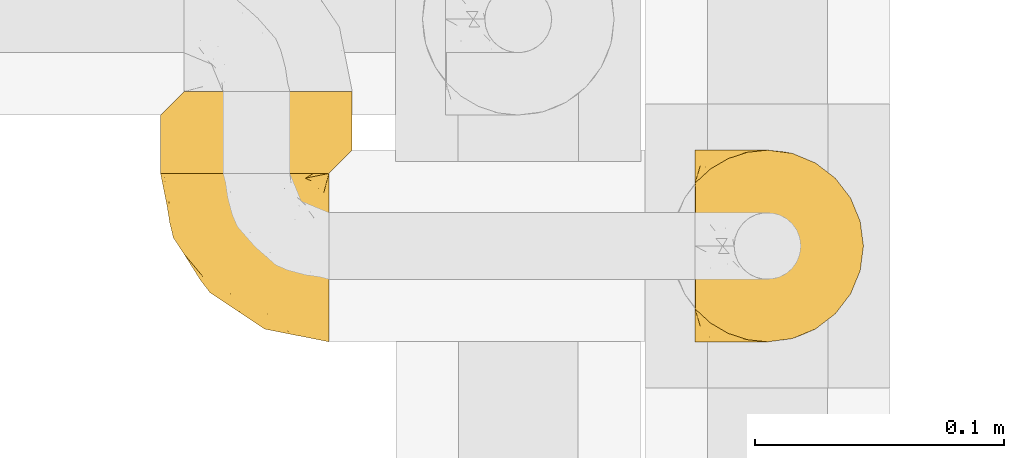
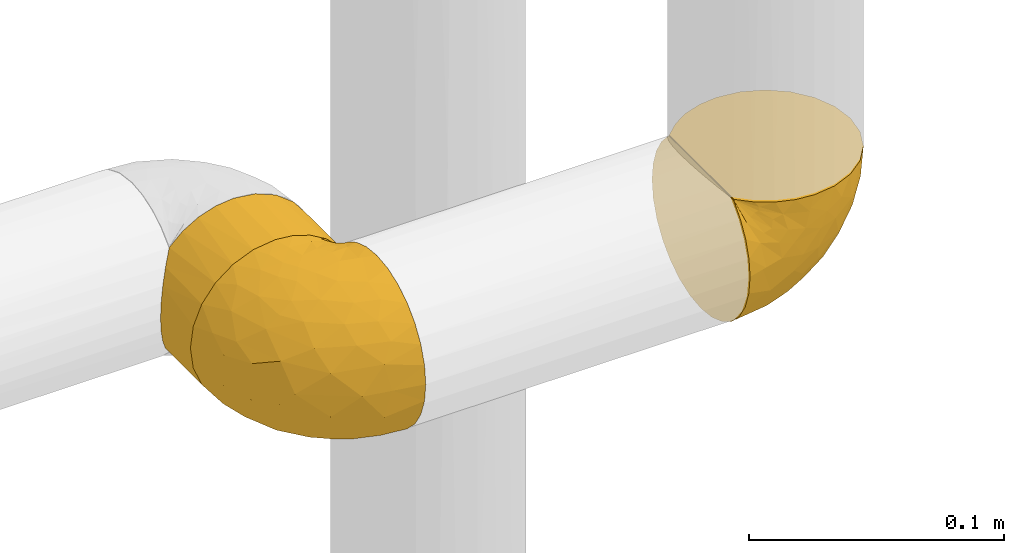
# One storey, part 497 of 827: 3 coverings.
"""IFC2X3 building model written with IfcOpenShell, lengths in millimetres."""

from ifc_helpers import new_model, entity, si_unit, converted_unit, derived_unit, direction, frame, origin, place, context, subcontext, project, spatial, faceted_brep, element, save


model = new_model("IFC2X3")

# Units and contexts
model_context = context("Model", 3, precision=0.01, world=origin(), true_north=direction((6.12303176911189e-17, 1.0)))
body_context = subcontext(model_context, "Body", "Model", "MODEL_VIEW")
ifc_project = project(units=[si_unit("LENGTHUNIT", "METRE", prefix="MILLI"), si_unit("AREAUNIT", "SQUARE_METRE"), si_unit("VOLUMEUNIT", "CUBIC_METRE"), converted_unit("PLANEANGLEUNIT", "DEGREE", entity("IfcRatioMeasure", 0.0174532925199433), si_unit("PLANEANGLEUNIT", "RADIAN"), dimensions=[0, 0, 0, 0, 0, 0, 0]), si_unit("MASSUNIT", "GRAM", prefix="KILO"), derived_unit("MASSDENSITYUNIT", [(si_unit("MASSUNIT", "GRAM", prefix="KILO"), 1), (si_unit("LENGTHUNIT", "METRE"), -3)]), derived_unit("MOMENTOFINERTIAUNIT", [(si_unit("LENGTHUNIT", "METRE"), 4)]), si_unit("TIMEUNIT", "SECOND"), si_unit("FREQUENCYUNIT", "HERTZ"), si_unit("THERMODYNAMICTEMPERATUREUNIT", "DEGREE_CELSIUS"), derived_unit("THERMALTRANSMITTANCEUNIT", [(si_unit("MASSUNIT", "GRAM", prefix="KILO"), 1), (si_unit("THERMODYNAMICTEMPERATUREUNIT", "KELVIN"), -1), (si_unit("TIMEUNIT", "SECOND"), -3)]), derived_unit("VOLUMETRICFLOWRATEUNIT", [(si_unit("LENGTHUNIT", "METRE"), 3), (si_unit("TIMEUNIT", "SECOND"), -1)]), derived_unit("MASSFLOWRATEUNIT", [(si_unit("MASSUNIT", "GRAM", prefix="KILO"), 1), (si_unit("TIMEUNIT", "SECOND"), -1)]), derived_unit("ROTATIONALFREQUENCYUNIT", [(si_unit("TIMEUNIT", "SECOND"), -1)]), si_unit("ELECTRICCURRENTUNIT", "AMPERE"), si_unit("ELECTRICVOLTAGEUNIT", "VOLT"), si_unit("POWERUNIT", "WATT"), si_unit("FORCEUNIT", "NEWTON", prefix="KILO"), si_unit("ILLUMINANCEUNIT", "LUX"), si_unit("LUMINOUSFLUXUNIT", "LUMEN"), si_unit("LUMINOUSINTENSITYUNIT", "CANDELA"), derived_unit("USERDEFINED", [(si_unit("MASSUNIT", "GRAM", prefix="KILO"), -1), (si_unit("LENGTHUNIT", "METRE"), -2), (si_unit("TIMEUNIT", "SECOND"), 3), (si_unit("LUMINOUSFLUXUNIT", "LUMEN"), 1)]), derived_unit("LINEARVELOCITYUNIT", [(si_unit("LENGTHUNIT", "METRE"), 1), (si_unit("TIMEUNIT", "SECOND"), -1)]), si_unit("PRESSUREUNIT", "PASCAL"), derived_unit("USERDEFINED", [(si_unit("LENGTHUNIT", "METRE"), -2), (si_unit("MASSUNIT", "GRAM", prefix="KILO"), 1), (si_unit("TIMEUNIT", "SECOND"), -2)]), derived_unit("LINEARFORCEUNIT", [(si_unit("MASSUNIT", "GRAM", prefix="KILO"), 1), (si_unit("LENGTHUNIT", "METRE"), 1), (si_unit("TIMEUNIT", "SECOND"), -2), (si_unit("LENGTHUNIT", "METRE"), -1)]), derived_unit("PLANARFORCEUNIT", [(si_unit("MASSUNIT", "GRAM", prefix="KILO"), 1), (si_unit("LENGTHUNIT", "METRE"), 1), (si_unit("TIMEUNIT", "SECOND"), -2), (si_unit("LENGTHUNIT", "METRE"), -2)])], contexts=[model_context])

# Site, building, storey
site_placement = place(None, origin())
site = spatial("IfcSite", under=ifc_project, at=site_placement, CompositionType="ELEMENT")
building_placement = place(site_placement, origin())
building = spatial("IfcBuilding", under=site, at=building_placement, CompositionType="ELEMENT")
storey_placement = place(building_placement, frame((0.0, 0.0, 28200.0)))
storey = spatial("IfcBuildingStorey", under=building, at=storey_placement, Name="08", CompositionType="ELEMENT", Elevation=28200.0)

# Coverings
covering_1_placement = place(storey_placement, frame((61121.94, 16248.83, 2609.95)))
element("IfcCovering", 1, at=covering_1_placement, inside=storey, Name=":ADSK_", ObjectType=":ADSK_", PredefinedType="INSULATION", context=body_context, shape_type="Brep", body=[
    faceted_brep([(1.6, 74.68, 23.36), (1.6, 70.1, 16.07), (1.6, 64.01, 9.98), (1.6, 56.72, 5.4), (1.6, 48.6, 2.56), (1.6, 40.05, 1.6), (1.6, 31.49, 2.56), (1.6, 23.36, 5.41), (1.6, 16.07, 9.99), (1.6, 9.98, 16.08), (1.6, 5.4, 23.37), (1.6, 2.56, 31.49), (1.6, 1.6, 40.05), (1.6, 2.46, 48.15), (1.6, 5.01, 55.88), (1.6, 9.13, 62.9), (1.6, 14.62, 68.89), (1.6, 16.82, 68.89), (1.6, 18.56, 68.89), (1.6, 20.52, 68.89), (1.6, 22.49, 68.89), (1.6, 24.46, 68.89), (1.6, 26.42, 68.89), (1.6, 28.39, 68.89), (1.6, 30.36, 68.89), (1.6, 32.55, 68.89), (1.6, 34.75, 68.89), (1.6, 36.94, 68.89), (1.6, 39.13, 68.89), (1.6, 41.33, 68.89), (1.6, 43.52, 68.89), (1.6, 45.72, 68.89), (1.6, 47.91, 68.89), (1.6, 50.11, 68.89), (1.6, 52.3, 68.89), (1.6, 54.49, 68.89), (1.6, 56.69, 68.89), (1.6, 58.88, 68.89), (1.6, 61.08, 68.89), (1.6, 63.27, 68.89), (1.6, 65.47, 68.89), (1.6, 70.97, 62.89), (1.6, 75.09, 55.86), (1.6, 77.64, 48.13), (1.6, 78.5, 40.05), (1.6, 77.53, 31.49), (1.85, 14.62, 69.15), (7.85, 9.12, 69.15), (14.87, 5.0, 69.15), (22.6, 2.46, 69.15), (30.7, 1.6, 69.15), (40.65, 2.91, 69.15), (49.92, 6.75, 69.15), (57.88, 12.86, 69.15), (63.99, 20.82, 69.15), (67.84, 30.09, 69.15), (69.15, 40.05, 69.15), (67.84, 50.0, 69.15), (63.99, 59.27, 69.15), (57.88, 67.23, 69.15), (49.92, 73.34, 69.15), (40.65, 77.19, 69.15), (30.7, 78.5, 69.15), (22.6, 77.63, 69.15), (14.87, 75.09, 69.15), (7.85, 70.97, 69.15), (1.85, 65.47, 69.15), (1.85, 63.27, 69.15), (1.85, 62.29, 69.15), (1.85, 60.7, 69.15), (1.85, 59.11, 69.15), (1.85, 57.52, 69.15), (1.85, 55.93, 69.15), (1.85, 54.34, 69.15), (1.85, 52.76, 69.15), (1.85, 51.17, 69.15), (1.85, 49.58, 69.15), (1.85, 47.99, 69.15), (1.85, 46.4, 69.15), (1.85, 44.81, 69.15), (1.85, 43.22, 69.15), (1.85, 41.63, 69.15), (1.85, 40.05, 69.15), (1.85, 38.46, 69.15), (1.85, 36.87, 69.15), (1.85, 35.28, 69.15), (1.85, 33.69, 69.15), (1.85, 32.1, 69.15), (1.85, 30.51, 69.15), (1.85, 28.92, 69.15), (1.85, 27.33, 69.15), (1.85, 25.37, 69.15), (1.85, 23.4, 69.15), (1.85, 21.21, 69.15), (1.85, 19.01, 69.15), (1.85, 16.82, 69.15), (1.77, 42.32, 68.96), (1.78, 44.02, 68.97), (1.77, 47.13, 68.97), (1.77, 48.74, 68.97), (1.76, 23.57, 68.95), (1.77, 25.13, 68.96), (1.79, 61.34, 68.98), (1.78, 22.02, 68.97), (1.78, 29.72, 68.97), (1.78, 56.73, 68.98), (1.78, 55.14, 68.97), (1.78, 37.66, 68.97), (1.74, 64.12, 68.94), (1.78, 28.13, 68.98), (1.78, 26.62, 68.98), (1.77, 31.46, 68.96), (1.78, 16.16, 68.97), (1.78, 39.16, 68.98), (1.78, 50.37, 68.98), (1.77, 17.69, 68.97), (1.77, 19.17, 68.96), (1.77, 62.78, 68.97), (1.78, 58.35, 68.97), (1.78, 45.53, 68.98), (1.77, 59.91, 68.96), (1.77, 65.47, 68.97), (1.72, 65.47, 68.94), (1.66, 65.47, 68.92), (1.77, 14.62, 68.97), (1.8, 14.62, 69.02), (1.82, 14.62, 69.08), (1.79, 20.59, 68.98), (1.78, 32.99, 68.97), (1.79, 34.48, 68.98), (1.78, 51.91, 68.97), (1.82, 65.47, 69.08), (1.8, 65.47, 69.02), (1.76, 53.48, 68.96), (1.66, 14.62, 68.92), (1.72, 14.62, 68.94), (1.78, 40.77, 68.97), (1.77, 35.97, 68.96), (9.41, 7.84, 67.02), (17.65, 3.53, 63.33), (7.41, 8.32, 64.61), (15.21, 2.19, 51.4), (7.41, 3.53, 53.1), (16.15, 1.6, 43.94), (28.75, 1.6, 61.87), (13.67, 4.57, 61.54), (12.79, 3.96, 57.95), (19.18, 2.28, 56.12), (29.16, 1.6, 63.4), (9.04, 7.69, 65.41), (5.74, 8.32, 63.04), (3.72, 7.84, 61.33), (8.87, 1.6, 41.99), (21.47, 1.6, 49.27), (26.8, 1.6, 54.6), (9.53, 4.34, 56.6), (7.34, 1.6, 41.58), (37.63, 29.63, 13.72), (17.92, 27.34, 5.82), (27.45, 40.05, 6.74), (37.01, 2.39, 58.82), (34.22, 2.43, 51.58), (45.87, 9.07, 42.09), (56.57, 16.64, 46.12), (52.31, 9.54, 55.56), (42.07, 4.52, 52.38), (44.74, 4.52, 61.54), (21.49, 7.49, 23.76), (11.02, 7.49, 20.5), (15.64, 12.85, 14.64), (26.02, 2.35, 41.77), (36.59, 22.66, 16.28), (65.49, 32.9, 49.4), (63.99, 25.33, 52.34), (15.2, 40.05, 4.3), (60.27, 16.64, 58.67), (45.25, 19.99, 25.26), (35.21, 16.37, 20.17), (22.52, 3.26, 34.7), (12.03, 3.75, 28.67), (13.32, 19.58, 8.62), (35.9, 7.5, 33.37), (33.87, 4.04, 41.35), (25.73, 13.94, 17.15), (26.34, 19.58, 12.68), (46.78, 28.21, 21.47), (59.54, 24.75, 41.11), (60.18, 31.42, 37.53), (53.93, 26.2, 30.64), (53.36, 33.36, 26.66), (49.36, 40.05, 21.38), (38.4, 40.05, 14.06), (66.44, 40.05, 55.54), (50.09, 16.14, 35.17), (41.08, 12.85, 29.04), (31.14, 10.47, 24.34), (28.19, 6.49, 29.33), (64.0, 40.05, 43.3), (56.68, 40.05, 32.34), (43.9, 75.57, 57.75), (65.46, 47.37, 49.41), (52.22, 52.91, 27.85), (37.61, 50.46, 13.7), (15.64, 67.23, 14.63), (13.31, 60.5, 8.61), (50.02, 70.55, 48.85), (59.28, 63.45, 54.13), (53.05, 62.61, 37.84), (21.48, 72.6, 23.75), (11.01, 72.6, 20.49), (12.03, 76.34, 28.66), (41.02, 59.34, 20.83), (35.39, 77.76, 55.15), (26.8, 78.5, 54.6), (28.75, 78.5, 61.87), (7.34, 78.5, 41.58), (65.81, 53.16, 57.58), (53.28, 70.55, 59.91), (59.8, 48.88, 36.94), (61.82, 54.76, 45.72), (17.91, 52.74, 5.82), (41.4, 71.93, 37.91), (40.48, 75.79, 50.18), (26.34, 60.5, 12.67), (31.68, 77.86, 49.29), (27.68, 77.64, 42.64), (16.15, 78.5, 43.94), (21.47, 78.5, 49.27), (28.05, 67.23, 19.45), (22.54, 76.82, 34.7), (8.87, 78.5, 41.99), (37.3, 77.8, 62.29), (41.07, 67.23, 29.01), (32.24, 73.2, 31.47), (47.4, 67.66, 37.18), (35.77, 75.99, 43.45), (17.65, 76.57, 63.33), (11.06, 73.21, 67.23), (8.55, 71.93, 66.07), (6.63, 71.07, 65.22), (12.77, 75.09, 61.99), (12.79, 76.13, 57.95), (7.41, 76.57, 53.09), (18.97, 77.69, 56.84), (3.72, 72.26, 61.33), (5.76, 71.77, 63.06), (15.21, 77.9, 51.41), (9.52, 75.75, 56.61)], [[[0, 1, 2, 3, 4, 5, 6, 7, 8, 9, 10, 11, 12, 13, 14, 15, 16, 17, 18, 19, 20, 21, 22, 23, 24, 25, 26, 27, 28, 29, 30, 31, 32, 33, 34, 35, 36, 37, 38, 39, 40, 41, 42, 43, 44, 45]], [[46, 47, 48, 49, 50, 51, 52, 53, 54, 55, 56, 57, 58, 59, 60, 61, 62, 63, 64, 65, 66, 67, 68, 69, 70, 71, 72, 73, 74, 75, 76, 77, 78, 79, 80, 81, 82, 83, 84, 85, 86, 87, 88, 89, 90, 91, 92, 93, 94, 95]], [[96, 97, 30]], [[98, 77, 99]], [[100, 101, 21]], [[69, 68, 102]], [[20, 19, 103]], [[24, 23, 104]], [[20, 103, 100]], [[72, 105, 106]], [[84, 83, 107]], [[89, 88, 104]], [[108, 67, 66]], [[109, 110, 90]], [[111, 25, 24]], [[112, 17, 16]], [[82, 113, 83]], [[109, 23, 22]], [[114, 76, 75]], [[105, 36, 106]], [[104, 111, 24]], [[18, 115, 116]], [[97, 96, 80]], [[67, 108, 117]], [[105, 71, 118]], [[31, 97, 119]], [[102, 120, 69]], [[108, 121, 122, 123, 40]], [[112, 95, 115]], [[17, 115, 18]], [[94, 116, 115]], [[117, 68, 67]], [[38, 117, 39]], [[112, 124, 125, 126, 46]], [[17, 112, 115]], [[70, 120, 118]], [[39, 117, 108]], [[120, 38, 37]], [[120, 37, 118]], [[120, 70, 69]], [[116, 94, 127]], [[128, 86, 129]], [[117, 38, 102]], [[74, 130, 75]], [[99, 33, 32]], [[115, 95, 94]], [[39, 108, 40]], [[108, 66, 131, 132, 121]], [[105, 72, 71]], [[118, 37, 36]], [[71, 70, 118]], [[35, 106, 36]], [[36, 105, 118]], [[35, 133, 106]], [[74, 73, 133]], [[106, 133, 73]], [[99, 114, 33]], [[133, 35, 34]], [[73, 72, 106]], [[95, 112, 46]], [[112, 16, 134, 135]], [[130, 114, 75]], [[99, 76, 114]], [[114, 130, 33]], [[34, 33, 130]], [[78, 77, 98]], [[98, 119, 78]], [[130, 133, 34]], [[133, 130, 74]], [[79, 97, 80]], [[98, 99, 32]], [[98, 32, 31]], [[77, 76, 99]], [[97, 79, 119]], [[136, 96, 29]], [[30, 97, 31]], [[136, 29, 28]], [[81, 80, 96]], [[29, 96, 30]], [[31, 119, 98]], [[119, 79, 78]], [[96, 136, 81]], [[82, 81, 136]], [[113, 107, 83]], [[84, 107, 137]], [[107, 27, 137]], [[113, 28, 107]], [[27, 107, 28]], [[85, 84, 137]], [[137, 27, 26]], [[113, 136, 28]], [[136, 113, 82]], [[109, 89, 104]], [[86, 85, 129]], [[89, 109, 90]], [[111, 87, 128]], [[26, 129, 137]], [[88, 111, 104]], [[25, 111, 128]], [[22, 110, 109]], [[23, 109, 104]], [[110, 91, 90]], [[100, 92, 101]], [[110, 22, 101]], [[91, 110, 101]], [[116, 19, 18]], [[111, 88, 87]], [[127, 103, 19]], [[25, 128, 26]], [[86, 128, 87]], [[128, 129, 26]], [[137, 129, 85]], [[120, 102, 38]], [[117, 102, 68]], [[91, 101, 92]], [[21, 101, 22]], [[93, 92, 103]], [[100, 21, 20]], [[100, 103, 92]], [[127, 93, 103]], [[93, 127, 94]], [[116, 127, 19]], [[126, 138, 47]], [[48, 138, 139]], [[140, 125, 124]], [[141, 142, 143]], [[144, 49, 139]], [[145, 140, 146]], [[48, 139, 49]], [[139, 145, 147]], [[49, 144, 148, 50]], [[126, 125, 149]], [[14, 13, 142]], [[150, 146, 140]], [[149, 140, 145]], [[151, 150, 135]], [[151, 14, 142]], [[16, 15, 134]], [[13, 152, 142]], [[124, 150, 140]], [[141, 143, 153]], [[14, 151, 15]], [[15, 151, 134]], [[47, 46, 126]], [[139, 154, 144]], [[138, 48, 47]], [[125, 140, 149]], [[135, 134, 151]], [[146, 155, 141]], [[145, 146, 147]], [[149, 139, 138]], [[147, 153, 154]], [[147, 146, 141]], [[139, 147, 154]], [[139, 149, 145]], [[149, 138, 126]], [[147, 141, 153]], [[146, 150, 155]], [[151, 155, 150]], [[142, 141, 155]], [[13, 12, 156, 152]], [[152, 143, 142]], [[151, 142, 155]], [[150, 124, 135]], [[157, 158, 159]], [[160, 154, 161]], [[162, 163, 164]], [[165, 166, 160]], [[167, 168, 169]], [[153, 170, 161]], [[156, 12, 11]], [[158, 157, 171]], [[172, 55, 173]], [[158, 6, 174]], [[175, 54, 53]], [[52, 166, 164]], [[52, 164, 53]], [[54, 175, 173]], [[166, 52, 51]], [[176, 177, 171]], [[178, 143, 179]], [[156, 11, 179]], [[8, 7, 180]], [[169, 9, 8]], [[179, 143, 152, 156]], [[179, 11, 10]], [[168, 179, 10]], [[181, 162, 182]], [[179, 167, 178]], [[183, 184, 177]], [[183, 169, 184]], [[176, 171, 185]], [[172, 186, 187]], [[158, 7, 6]], [[159, 158, 174]], [[184, 180, 158]], [[54, 173, 55]], [[180, 169, 8]], [[188, 189, 187]], [[9, 168, 10]], [[186, 188, 187]], [[190, 157, 159, 191]], [[55, 172, 192]], [[176, 193, 194]], [[161, 170, 182]], [[162, 164, 165]], [[175, 164, 163]], [[51, 50, 148]], [[167, 195, 196]], [[178, 182, 170]], [[6, 5, 174]], [[158, 180, 7]], [[169, 180, 184]], [[169, 168, 9]], [[179, 168, 167]], [[182, 162, 165]], [[162, 194, 193]], [[161, 165, 160]], [[195, 181, 196]], [[192, 172, 197]], [[192, 56, 55]], [[189, 190, 198]], [[198, 197, 187]], [[172, 187, 197]], [[185, 189, 188]], [[198, 187, 189]], [[186, 172, 173]], [[173, 163, 186]], [[193, 186, 163]], [[176, 185, 188]], [[185, 157, 190]], [[188, 186, 193]], [[177, 176, 194]], [[188, 193, 176]], [[162, 193, 163]], [[195, 177, 194]], [[171, 177, 184]], [[181, 195, 194]], [[183, 167, 169]], [[162, 181, 194]], [[196, 182, 178]], [[158, 171, 184]], [[171, 157, 185]], [[177, 195, 183]], [[167, 183, 195]], [[182, 196, 181]], [[178, 170, 143]], [[178, 167, 196]], [[164, 175, 53]], [[173, 175, 163]], [[160, 51, 148]], [[164, 166, 165]], [[51, 160, 166]], [[160, 148, 144, 154]], [[153, 161, 154]], [[182, 165, 161]], [[190, 189, 185]], [[143, 170, 153]], [[60, 199, 61]], [[197, 200, 192]], [[201, 190, 202]], [[200, 57, 192]], [[203, 204, 2]], [[205, 206, 207]], [[208, 209, 210]], [[211, 207, 201]], [[212, 213, 214]], [[45, 215, 210]], [[216, 206, 58]], [[45, 44, 215]], [[59, 217, 60]], [[60, 217, 199]], [[0, 45, 210]], [[218, 201, 219]], [[202, 159, 220]], [[205, 221, 222]], [[223, 204, 203]], [[1, 203, 2]], [[57, 200, 216]], [[220, 3, 204]], [[220, 174, 4]], [[1, 0, 209]], [[212, 224, 213]], [[225, 226, 227]], [[228, 223, 203]], [[208, 210, 229]], [[210, 226, 229]], [[3, 220, 4]], [[58, 206, 59]], [[209, 203, 1]], [[202, 220, 223]], [[228, 203, 208]], [[202, 211, 201]], [[3, 2, 204]], [[202, 190, 191, 159]], [[210, 215, 230, 226]], [[199, 212, 231]], [[232, 233, 221]], [[233, 208, 229]], [[207, 206, 219]], [[217, 206, 205]], [[227, 224, 225]], [[233, 232, 228]], [[201, 207, 219]], [[234, 232, 221]], [[218, 219, 200]], [[202, 223, 211]], [[174, 220, 159]], [[174, 5, 4]], [[61, 231, 62]], [[220, 204, 223]], [[210, 209, 0]], [[203, 209, 208]], [[225, 233, 229]], [[224, 227, 213]], [[221, 233, 235]], [[57, 56, 192]], [[198, 218, 197]], [[200, 219, 216]], [[201, 198, 190]], [[197, 218, 200]], [[198, 201, 218]], [[206, 216, 219]], [[58, 57, 216]], [[231, 212, 214]], [[222, 212, 199]], [[228, 211, 223]], [[207, 211, 232]], [[62, 231, 214]], [[199, 231, 61]], [[233, 228, 208]], [[211, 228, 232]], [[222, 221, 235]], [[234, 205, 207]], [[206, 217, 59]], [[199, 217, 205]], [[205, 222, 199]], [[224, 222, 235]], [[222, 224, 212]], [[224, 235, 225]], [[233, 225, 235]], [[226, 225, 229]], [[205, 234, 221]], [[207, 232, 234]], [[63, 214, 236]], [[214, 213, 236]], [[214, 63, 62]], [[237, 236, 238]], [[238, 132, 131]], [[236, 237, 64]], [[239, 240, 241]], [[63, 236, 64]], [[131, 66, 65]], [[237, 131, 65]], [[242, 230, 43]], [[237, 65, 64]], [[239, 121, 132]], [[42, 242, 43]], [[241, 240, 243]], [[41, 123, 244]], [[43, 230, 215, 44]], [[244, 122, 245]], [[227, 246, 243]], [[241, 247, 245]], [[121, 239, 245]], [[41, 40, 123]], [[132, 238, 239]], [[244, 42, 41]], [[131, 237, 238]], [[240, 239, 238]], [[245, 239, 241]], [[247, 241, 246]], [[247, 244, 245]], [[238, 236, 240]], [[243, 236, 213]], [[236, 243, 240]], [[227, 226, 246]], [[243, 213, 227]], [[242, 246, 226]], [[243, 246, 241]], [[246, 242, 247]], [[244, 247, 242]], [[242, 226, 230]], [[42, 244, 242]], [[122, 244, 123]], [[122, 121, 245]], [[112, 135, 124]]]),
])
covering_2_placement = place(storey_placement, frame((60907.64, 16316.38, 2610.0)))
element("IfcCovering", 2, at=covering_2_placement, inside=storey, Name=":ADSK_", ObjectType=":ADSK_", PredefinedType="INSULATION", context=body_context, shape_type="Brep", body=[
    faceted_brep([(31.79, 34.36, 77.51), (40.0, 34.36, 78.4), (49.93, 34.36, 77.09), (59.2, 34.36, 73.25), (67.15, 34.36, 67.15), (73.25, 34.36, 59.2), (77.09, 34.36, 49.93), (78.4, 34.36, 40.0), (77.09, 34.36, 30.06), (73.25, 34.36, 20.8), (67.15, 34.36, 12.84), (59.2, 34.36, 6.74), (49.93, 34.36, 2.9), (40.0, 34.36, 1.6), (31.79, 34.36, 2.48), (23.98, 34.36, 5.09), (16.91, 34.36, 9.31), (10.9, 34.36, 14.94), (10.9, 34.36, 65.05), (16.91, 34.36, 70.68), (23.98, 34.36, 74.9), (30.06, 1.6, 77.09), (20.8, 1.6, 73.25), (12.84, 1.6, 67.15), (6.74, 1.6, 59.2), (2.9, 1.6, 49.93), (1.6, 1.6, 40.0), (2.9, 1.6, 30.06), (6.74, 1.6, 20.8), (12.84, 1.6, 12.84), (20.8, 1.6, 6.74), (30.06, 1.6, 2.9), (40.0, 1.6, 1.6), (48.2, 1.6, 2.48), (56.01, 1.6, 5.09), (63.08, 1.6, 9.31), (69.1, 1.6, 14.94), (69.1, 1.6, 65.05), (63.08, 1.6, 70.68), (56.01, 1.6, 74.9), (48.2, 1.6, 77.51), (40.0, 1.6, 78.4), (77.79, 10.29, 33.21), (76.0, 8.5, 26.63), (73.07, 5.57, 20.48), (78.4, 10.9, 40.0), (4.0, 27.46, 26.63), (2.2, 25.66, 33.21), (1.6, 25.06, 40.0), (6.92, 30.38, 20.48), (2.2, 25.66, 46.78), (4.0, 27.46, 53.36), (6.92, 30.38, 59.51), (73.07, 5.57, 59.51), (76.0, 8.5, 53.36), (77.79, 10.29, 46.78)], [[[0, 1, 2, 3, 4, 5, 6, 7, 8, 9, 10, 11, 12, 13, 14, 15, 16, 17, 18, 19, 20]], [[21, 22, 23, 24, 25, 26, 27, 28, 29, 30, 31, 32, 33, 34, 35, 36, 37, 38, 39, 40, 41]], [[42, 43, 8]], [[9, 44, 10]], [[43, 44, 9]], [[45, 42, 7]], [[7, 42, 8]], [[43, 9, 8]], [[44, 36, 10]], [[11, 35, 34]], [[34, 33, 12]], [[32, 13, 33]], [[11, 10, 35]], [[12, 11, 34]], [[33, 13, 12]], [[35, 10, 36]], [[14, 32, 31]], [[31, 30, 15]], [[29, 16, 30]], [[13, 32, 14]], [[15, 14, 31]], [[16, 15, 30]], [[29, 17, 16]], [[46, 28, 27]], [[27, 26, 47]], [[48, 47, 26]], [[17, 29, 49]], [[47, 46, 27]], [[49, 28, 46]], [[49, 29, 28]], [[50, 48, 26]], [[50, 26, 25]], [[51, 25, 24]], [[51, 50, 25]], [[23, 18, 52]], [[51, 24, 52]], [[52, 24, 23]], [[19, 23, 22]], [[21, 41, 0]], [[20, 22, 21]], [[19, 22, 20]], [[1, 0, 41]], [[21, 0, 20]], [[23, 19, 18]], [[1, 41, 40]], [[40, 39, 2]], [[38, 3, 39]], [[1, 40, 2]], [[3, 2, 39]], [[4, 3, 38]], [[38, 37, 4]], [[53, 5, 4]], [[54, 55, 6]], [[53, 54, 5]], [[5, 54, 6]], [[7, 6, 55]], [[45, 7, 55]], [[53, 4, 37]], [[50, 51, 52, 18, 17, 49, 46, 47, 48]], [[36, 44, 43, 42, 45, 55, 54, 53, 37]]]),
])
covering_3_placement = place(storey_placement, frame((60907.59, 16248.83, 2609.95)))
element("IfcCovering", 3, at=covering_3_placement, inside=storey, Name=":ADSK_", ObjectType=":ADSK_", PredefinedType="INSULATION", context=body_context, shape_type="Brep", body=[
    faceted_brep([(69.15, 23.36, 74.68), (69.15, 16.07, 70.1), (69.15, 9.98, 64.01), (69.15, 5.4, 56.72), (69.15, 2.56, 48.6), (69.15, 1.6, 40.05), (69.15, 2.56, 31.49), (69.15, 5.41, 23.36), (69.15, 9.99, 16.07), (69.15, 16.08, 9.98), (69.15, 23.37, 5.4), (69.15, 31.49, 2.56), (69.15, 40.05, 1.6), (69.15, 48.15, 2.46), (69.15, 55.88, 5.01), (69.15, 62.9, 9.13), (69.15, 68.89, 14.62), (69.15, 68.89, 16.82), (69.15, 68.89, 18.56), (69.15, 68.89, 20.52), (69.15, 68.89, 22.49), (69.15, 68.89, 24.46), (69.15, 68.89, 26.42), (69.15, 68.89, 28.39), (69.15, 68.89, 30.36), (69.15, 68.89, 32.55), (69.15, 68.89, 34.75), (69.15, 68.89, 36.94), (69.15, 68.89, 39.13), (69.15, 68.89, 41.33), (69.15, 68.89, 43.52), (69.15, 68.89, 45.72), (69.15, 68.89, 47.91), (69.15, 68.89, 50.11), (69.15, 68.89, 52.3), (69.15, 68.89, 54.49), (69.15, 68.89, 56.69), (69.15, 68.89, 58.88), (69.15, 68.89, 61.08), (69.15, 68.89, 63.27), (69.15, 68.89, 65.47), (69.15, 62.89, 70.97), (69.15, 55.86, 75.09), (69.15, 48.13, 77.64), (69.15, 40.05, 78.5), (69.15, 31.49, 77.53), (68.89, 69.15, 14.62), (62.89, 69.15, 9.12), (55.87, 69.15, 5.0), (48.14, 69.15, 2.46), (40.05, 69.15, 1.6), (30.09, 69.15, 2.91), (20.82, 69.15, 6.75), (12.86, 69.15, 12.86), (6.75, 69.15, 20.82), (2.91, 69.15, 30.09), (1.6, 69.15, 40.05), (2.91, 69.15, 50.0), (6.75, 69.15, 59.27), (12.86, 69.15, 67.23), (20.82, 69.15, 73.34), (30.09, 69.15, 77.19), (40.05, 69.15, 78.5), (48.14, 69.15, 77.63), (55.87, 69.15, 75.09), (62.89, 69.15, 70.97), (68.89, 69.15, 65.47), (68.89, 69.15, 63.27), (68.89, 69.15, 62.29), (68.89, 69.15, 60.7), (68.89, 69.15, 59.11), (68.89, 69.15, 57.52), (68.89, 69.15, 55.93), (68.89, 69.15, 54.34), (68.89, 69.15, 52.76), (68.89, 69.15, 51.17), (68.89, 69.15, 49.58), (68.89, 69.15, 47.99), (68.89, 69.15, 46.4), (68.89, 69.15, 44.81), (68.89, 69.15, 43.22), (68.89, 69.15, 41.63), (68.89, 69.15, 40.05), (68.89, 69.15, 38.46), (68.89, 69.15, 36.87), (68.89, 69.15, 35.28), (68.89, 69.15, 33.69), (68.89, 69.15, 32.1), (68.89, 69.15, 30.51), (68.89, 69.15, 28.92), (68.89, 69.15, 27.33), (68.89, 69.15, 25.37), (68.89, 69.15, 23.4), (68.89, 69.15, 21.21), (68.89, 69.15, 19.01), (68.89, 69.15, 16.82), (68.97, 68.96, 42.32), (68.96, 68.97, 44.02), (68.97, 68.97, 47.13), (68.97, 68.97, 48.74), (68.98, 68.95, 23.57), (68.97, 68.96, 25.13), (68.96, 68.98, 61.34), (68.96, 68.97, 22.02), (68.96, 68.97, 29.72), (68.96, 68.98, 56.73), (68.96, 68.97, 55.14), (68.96, 68.97, 37.66), (69.0, 68.94, 64.12), (68.96, 68.98, 28.13), (68.96, 68.98, 26.62), (68.97, 68.96, 31.46), (68.96, 68.97, 16.16), (68.96, 68.98, 39.16), (68.96, 68.98, 50.37), (68.97, 68.97, 17.69), (68.97, 68.96, 19.17), (68.97, 68.97, 62.78), (68.96, 68.97, 58.35), (68.96, 68.98, 45.53), (68.97, 68.96, 59.91), (68.97, 68.97, 65.47), (69.02, 68.94, 65.47), (69.08, 68.92, 65.47), (68.97, 68.97, 14.62), (68.94, 69.02, 14.62), (68.92, 69.08, 14.62), (68.96, 68.98, 20.59), (68.96, 68.97, 32.99), (68.95, 68.98, 34.48), (68.96, 68.97, 51.91), (68.92, 69.08, 65.47), (68.94, 69.02, 65.47), (68.98, 68.96, 53.48), (69.08, 68.92, 14.62), (69.02, 68.94, 14.62), (68.96, 68.97, 40.77), (68.97, 68.96, 35.97), (61.33, 67.02, 7.84), (53.1, 63.33, 3.53), (63.33, 64.61, 8.32), (49.27, 49.27, 1.6), (55.53, 51.4, 2.19), (54.6, 43.94, 1.6), (41.99, 61.87, 1.6), (57.07, 61.54, 4.57), (57.95, 57.95, 3.96), (51.56, 56.12, 2.28), (41.58, 63.4, 1.6), (61.7, 65.41, 7.69), (63.33, 53.1, 3.53), (65.0, 63.04, 8.32), (67.02, 61.33, 7.84), (61.87, 41.99, 1.6), (43.94, 54.6, 1.6), (61.21, 56.6, 4.34), (63.4, 41.58, 1.6), (33.11, 13.72, 29.63), (52.82, 5.82, 27.34), (43.3, 6.74, 40.05), (33.73, 58.82, 2.39), (36.52, 51.58, 2.43), (24.87, 42.09, 9.07), (14.17, 46.12, 16.64), (18.43, 55.56, 9.54), (28.67, 52.38, 4.52), (26.0, 61.54, 4.52), (49.25, 23.76, 7.49), (59.72, 20.5, 7.49), (55.1, 14.64, 12.85), (44.72, 41.77, 2.35), (34.15, 16.28, 22.66), (5.25, 49.4, 32.9), (6.75, 52.34, 25.33), (55.54, 4.3, 40.05), (10.47, 58.67, 16.64), (25.49, 25.26, 19.99), (35.53, 20.17, 16.37), (48.22, 34.7, 3.26), (58.71, 28.67, 3.75), (57.42, 8.62, 19.58), (34.84, 33.37, 7.5), (36.87, 41.35, 4.04), (45.01, 17.15, 13.94), (44.4, 12.68, 19.58), (23.96, 21.47, 28.21), (11.2, 41.11, 24.75), (10.56, 37.53, 31.42), (16.81, 30.64, 26.2), (17.38, 26.66, 33.36), (21.38, 21.38, 40.05), (32.34, 14.06, 40.05), (4.3, 55.54, 40.05), (20.65, 35.17, 16.14), (29.66, 29.04, 12.85), (39.6, 24.34, 10.47), (42.55, 29.33, 6.49), (6.74, 43.3, 40.05), (14.06, 32.34, 40.05), (26.84, 57.75, 75.57), (5.28, 49.41, 47.37), (18.52, 27.85, 52.91), (33.13, 13.7, 50.46), (55.1, 14.63, 67.23), (57.43, 8.61, 60.5), (20.72, 48.85, 70.55), (11.46, 54.13, 63.45), (17.69, 37.84, 62.61), (49.26, 23.75, 72.6), (59.73, 20.49, 72.6), (58.71, 28.66, 76.34), (29.72, 20.83, 59.34), (35.35, 55.15, 77.76), (43.94, 54.6, 78.5), (41.99, 61.87, 78.5), (63.4, 41.58, 78.5), (4.93, 57.58, 53.16), (17.46, 59.91, 70.55), (10.94, 36.94, 48.88), (8.92, 45.72, 54.76), (52.83, 5.82, 52.74), (29.34, 37.91, 71.93), (30.26, 50.18, 75.79), (44.4, 12.67, 60.5), (39.06, 49.29, 77.86), (43.06, 42.64, 77.64), (54.6, 43.94, 78.5), (49.27, 49.27, 78.5), (42.69, 19.45, 67.23), (48.2, 34.7, 76.82), (61.87, 41.99, 78.5), (33.44, 62.29, 77.8), (29.67, 29.01, 67.23), (38.5, 31.47, 73.2), (23.35, 37.18, 67.66), (34.97, 43.45, 75.99), (53.1, 63.33, 76.57), (59.68, 67.23, 73.21), (62.19, 66.07, 71.93), (64.11, 65.22, 71.07), (57.97, 61.99, 75.09), (57.95, 57.95, 76.13), (63.33, 53.09, 76.57), (51.77, 56.84, 77.69), (67.02, 61.33, 72.26), (64.98, 63.06, 71.77), (55.53, 51.41, 77.9), (61.22, 56.61, 75.75)], [[[0, 1, 2, 3, 4, 5, 6, 7, 8, 9, 10, 11, 12, 13, 14, 15, 16, 17, 18, 19, 20, 21, 22, 23, 24, 25, 26, 27, 28, 29, 30, 31, 32, 33, 34, 35, 36, 37, 38, 39, 40, 41, 42, 43, 44, 45]], [[46, 47, 48, 49, 50, 51, 52, 53, 54, 55, 56, 57, 58, 59, 60, 61, 62, 63, 64, 65, 66, 67, 68, 69, 70, 71, 72, 73, 74, 75, 76, 77, 78, 79, 80, 81, 82, 83, 84, 85, 86, 87, 88, 89, 90, 91, 92, 93, 94, 95]], [[96, 97, 30]], [[98, 77, 99]], [[100, 101, 21]], [[69, 68, 102]], [[20, 19, 103]], [[24, 23, 104]], [[20, 103, 100]], [[72, 105, 106]], [[84, 83, 107]], [[89, 88, 104]], [[108, 67, 66]], [[109, 110, 90]], [[111, 25, 24]], [[112, 17, 16]], [[82, 113, 83]], [[109, 23, 22]], [[114, 76, 75]], [[105, 36, 106]], [[104, 111, 24]], [[18, 115, 116]], [[97, 96, 80]], [[67, 108, 117]], [[105, 71, 118]], [[31, 97, 119]], [[102, 120, 69]], [[108, 121, 122, 123, 40]], [[112, 95, 115]], [[17, 115, 18]], [[94, 116, 115]], [[117, 68, 67]], [[38, 117, 39]], [[112, 124, 125, 126, 46]], [[17, 112, 115]], [[70, 120, 118]], [[39, 117, 108]], [[120, 38, 37]], [[120, 37, 118]], [[120, 70, 69]], [[116, 94, 127]], [[128, 86, 129]], [[117, 38, 102]], [[74, 130, 75]], [[99, 33, 32]], [[115, 95, 94]], [[39, 108, 40]], [[108, 66, 131, 132, 121]], [[105, 72, 71]], [[118, 37, 36]], [[71, 70, 118]], [[35, 106, 36]], [[36, 105, 118]], [[35, 133, 106]], [[74, 73, 133]], [[106, 133, 73]], [[99, 114, 33]], [[133, 35, 34]], [[73, 72, 106]], [[95, 112, 46]], [[112, 16, 134, 135, 124]], [[130, 114, 75]], [[99, 76, 114]], [[114, 130, 33]], [[34, 33, 130]], [[78, 77, 98]], [[98, 119, 78]], [[130, 133, 34]], [[133, 130, 74]], [[79, 97, 80]], [[98, 99, 32]], [[98, 32, 31]], [[77, 76, 99]], [[97, 79, 119]], [[136, 96, 29]], [[30, 97, 31]], [[136, 29, 28]], [[81, 80, 96]], [[29, 96, 30]], [[31, 119, 98]], [[119, 79, 78]], [[96, 136, 81]], [[82, 81, 136]], [[113, 107, 83]], [[84, 107, 137]], [[107, 27, 137]], [[113, 28, 107]], [[27, 107, 28]], [[85, 84, 137]], [[137, 27, 26]], [[113, 136, 28]], [[136, 113, 82]], [[109, 89, 104]], [[86, 85, 129]], [[89, 109, 90]], [[111, 87, 128]], [[26, 129, 137]], [[88, 111, 104]], [[25, 111, 128]], [[22, 110, 109]], [[23, 109, 104]], [[110, 91, 90]], [[100, 92, 101]], [[110, 22, 101]], [[91, 110, 101]], [[116, 19, 18]], [[111, 88, 87]], [[127, 103, 19]], [[25, 128, 26]], [[86, 128, 87]], [[128, 129, 26]], [[137, 129, 85]], [[120, 102, 38]], [[117, 102, 68]], [[91, 101, 92]], [[21, 101, 22]], [[93, 92, 103]], [[100, 21, 20]], [[100, 103, 92]], [[127, 93, 103]], [[93, 127, 94]], [[116, 127, 19]], [[126, 138, 47]], [[48, 138, 139]], [[140, 125, 124]], [[141, 142, 143]], [[144, 49, 139]], [[145, 140, 146]], [[48, 139, 49]], [[139, 145, 147]], [[49, 144, 148, 50]], [[126, 125, 149]], [[14, 13, 150]], [[151, 146, 140]], [[149, 140, 145]], [[152, 151, 135]], [[152, 14, 150]], [[16, 15, 134]], [[13, 153, 150]], [[124, 151, 140]], [[141, 147, 142]], [[14, 152, 15]], [[15, 152, 134]], [[47, 46, 126]], [[139, 154, 144]], [[138, 48, 47]], [[125, 140, 149]], [[135, 134, 152]], [[146, 155, 142]], [[145, 146, 147]], [[149, 139, 138]], [[147, 141, 154]], [[147, 146, 142]], [[139, 147, 154]], [[139, 149, 145]], [[149, 138, 126]], [[155, 146, 151]], [[150, 143, 142]], [[152, 155, 151]], [[150, 142, 155]], [[13, 12, 156, 153]], [[153, 143, 150]], [[152, 150, 155]], [[151, 124, 135]], [[157, 158, 159]], [[160, 154, 161]], [[162, 163, 164]], [[165, 166, 160]], [[167, 168, 169]], [[141, 170, 161]], [[156, 12, 11]], [[158, 157, 171]], [[172, 55, 173]], [[158, 6, 174]], [[175, 54, 53]], [[52, 166, 164]], [[52, 164, 53]], [[54, 175, 173]], [[166, 52, 51]], [[176, 177, 171]], [[178, 143, 179]], [[156, 11, 179]], [[8, 7, 180]], [[169, 9, 8]], [[179, 143, 153, 156]], [[179, 11, 10]], [[168, 179, 10]], [[181, 162, 182]], [[179, 167, 178]], [[183, 184, 177]], [[183, 169, 184]], [[176, 171, 185]], [[172, 186, 187]], [[158, 7, 6]], [[159, 158, 174]], [[184, 180, 158]], [[54, 173, 55]], [[180, 169, 8]], [[188, 189, 187]], [[9, 168, 10]], [[186, 188, 187]], [[190, 157, 159, 191]], [[55, 172, 192]], [[176, 193, 194]], [[161, 170, 182]], [[162, 164, 165]], [[175, 164, 163]], [[51, 50, 148]], [[167, 195, 196]], [[178, 182, 170]], [[6, 5, 174]], [[158, 180, 7]], [[169, 180, 184]], [[169, 168, 9]], [[179, 168, 167]], [[182, 162, 165]], [[162, 194, 193]], [[161, 165, 160]], [[195, 181, 196]], [[192, 172, 197]], [[192, 56, 55]], [[189, 190, 198]], [[198, 197, 187]], [[172, 187, 197]], [[185, 189, 188]], [[198, 187, 189]], [[186, 172, 173]], [[173, 163, 186]], [[193, 186, 163]], [[176, 185, 188]], [[185, 157, 190]], [[188, 186, 193]], [[177, 176, 194]], [[188, 193, 176]], [[162, 193, 163]], [[195, 177, 194]], [[171, 177, 184]], [[181, 195, 194]], [[183, 167, 169]], [[162, 181, 194]], [[196, 182, 178]], [[158, 171, 184]], [[171, 157, 185]], [[177, 195, 183]], [[167, 183, 195]], [[182, 196, 181]], [[178, 170, 143]], [[178, 167, 196]], [[164, 175, 53]], [[173, 175, 163]], [[160, 51, 148]], [[164, 166, 165]], [[51, 160, 166]], [[160, 148, 144, 154]], [[141, 161, 154]], [[182, 165, 161]], [[190, 189, 185]], [[143, 170, 141]], [[60, 199, 61]], [[197, 200, 192]], [[201, 190, 202]], [[200, 57, 192]], [[203, 204, 2]], [[205, 206, 207]], [[208, 209, 210]], [[211, 207, 201]], [[212, 213, 214]], [[45, 215, 210]], [[216, 206, 58]], [[45, 44, 215]], [[59, 217, 60]], [[60, 217, 199]], [[0, 45, 210]], [[218, 201, 219]], [[202, 159, 220]], [[205, 221, 222]], [[223, 204, 203]], [[1, 203, 2]], [[57, 200, 216]], [[220, 3, 204]], [[220, 174, 4]], [[1, 0, 209]], [[212, 224, 213]], [[225, 226, 227]], [[228, 223, 203]], [[208, 210, 229]], [[210, 226, 229]], [[3, 220, 4]], [[58, 206, 59]], [[209, 203, 1]], [[202, 220, 223]], [[228, 203, 208]], [[202, 211, 201]], [[3, 2, 204]], [[202, 190, 191, 159]], [[210, 215, 230, 226]], [[199, 212, 231]], [[232, 233, 221]], [[233, 208, 229]], [[207, 206, 219]], [[217, 206, 205]], [[227, 224, 225]], [[233, 232, 228]], [[201, 207, 219]], [[234, 232, 221]], [[218, 219, 200]], [[202, 223, 211]], [[174, 220, 159]], [[174, 5, 4]], [[61, 231, 62]], [[220, 204, 223]], [[210, 209, 0]], [[203, 209, 208]], [[225, 233, 229]], [[224, 227, 213]], [[221, 233, 235]], [[57, 56, 192]], [[198, 218, 197]], [[200, 219, 216]], [[201, 198, 190]], [[197, 218, 200]], [[198, 201, 218]], [[206, 216, 219]], [[58, 57, 216]], [[231, 212, 214]], [[222, 212, 199]], [[228, 211, 223]], [[207, 211, 232]], [[62, 231, 214]], [[199, 231, 61]], [[233, 228, 208]], [[211, 228, 232]], [[222, 221, 235]], [[234, 205, 207]], [[206, 217, 59]], [[199, 217, 205]], [[205, 222, 199]], [[224, 222, 235]], [[222, 224, 212]], [[224, 235, 225]], [[233, 225, 235]], [[226, 225, 229]], [[205, 234, 221]], [[207, 232, 234]], [[63, 214, 236]], [[214, 213, 236]], [[214, 63, 62]], [[237, 236, 238]], [[238, 132, 131]], [[236, 237, 64]], [[239, 240, 241]], [[63, 236, 64]], [[131, 66, 65]], [[237, 131, 65]], [[242, 230, 43]], [[237, 65, 64]], [[239, 121, 132]], [[42, 242, 43]], [[241, 240, 243]], [[41, 123, 244]], [[43, 230, 215, 44]], [[244, 122, 245]], [[227, 246, 243]], [[241, 247, 245]], [[121, 239, 245]], [[41, 40, 123]], [[132, 238, 239]], [[244, 42, 41]], [[131, 237, 238]], [[240, 239, 238]], [[245, 239, 241]], [[247, 241, 246]], [[247, 244, 245]], [[238, 236, 240]], [[243, 236, 213]], [[236, 243, 240]], [[227, 226, 246]], [[243, 213, 227]], [[242, 246, 226]], [[243, 246, 241]], [[246, 242, 247]], [[244, 247, 242]], [[242, 226, 230]], [[42, 244, 242]], [[122, 244, 123]], [[122, 121, 245]]]),
])

save(model, "model.ifc")
